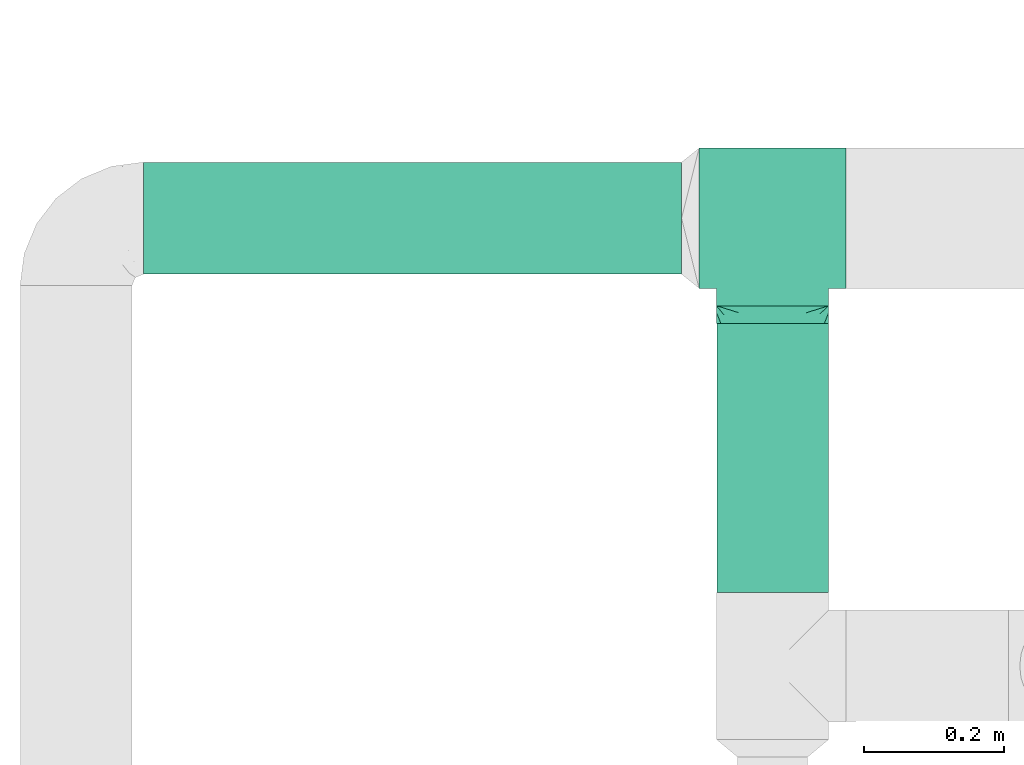
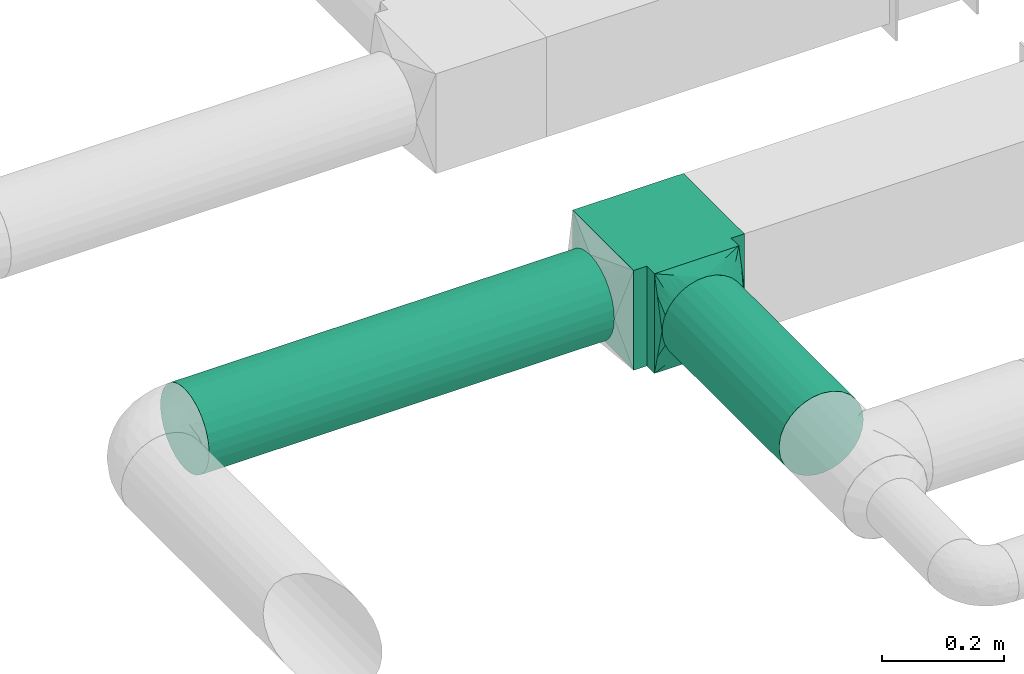
# One storey, part 4 of 12: 2 flow fittings, 2 flow segments.
"""IFC2X3 building model written with IfcOpenShell, lengths in millimetres."""

from ifc_helpers import new_model, entity, si_unit, converted_unit, derived_unit, direction, frame, origin, origin_2d_with_axis, place, context, subcontext, project, spatial, polyline, circle, outline, extrude, faceted_brep, source, transform, mapped, material, type_object, type_shapes, element, save


model = new_model("IFC2X3")

# Units and contexts
model_context = context("Model", 3, precision=0.01, world=origin(), true_north=direction((6.12303176911189e-17, 1.0)))
body_context = subcontext(model_context, "Body", "Model", "MODEL_VIEW")
ifc_project = project(units=[si_unit("LENGTHUNIT", "METRE", prefix="MILLI"), si_unit("AREAUNIT", "SQUARE_METRE"), si_unit("VOLUMEUNIT", "CUBIC_METRE"), converted_unit("PLANEANGLEUNIT", "DEGREE", entity("IfcRatioMeasure", 0.0174532925199433), si_unit("PLANEANGLEUNIT", "RADIAN"), dimensions=[0, 0, 0, 0, 0, 0, 0]), si_unit("MASSUNIT", "GRAM", prefix="KILO"), derived_unit("MASSDENSITYUNIT", [(si_unit("MASSUNIT", "GRAM", prefix="KILO"), 1), (si_unit("LENGTHUNIT", "METRE"), -3)]), si_unit("TIMEUNIT", "SECOND"), si_unit("FREQUENCYUNIT", "HERTZ"), si_unit("THERMODYNAMICTEMPERATUREUNIT", "DEGREE_CELSIUS"), derived_unit("THERMALTRANSMITTANCEUNIT", [(si_unit("MASSUNIT", "GRAM", prefix="KILO"), 1), (si_unit("THERMODYNAMICTEMPERATUREUNIT", "KELVIN"), -1), (si_unit("TIMEUNIT", "SECOND"), -3)]), derived_unit("VOLUMETRICFLOWRATEUNIT", [(si_unit("LENGTHUNIT", "METRE"), 3), (si_unit("TIMEUNIT", "SECOND"), -1)]), si_unit("ELECTRICCURRENTUNIT", "AMPERE"), si_unit("ELECTRICVOLTAGEUNIT", "VOLT"), si_unit("POWERUNIT", "WATT"), si_unit("FORCEUNIT", "NEWTON", prefix="KILO"), si_unit("ILLUMINANCEUNIT", "LUX"), si_unit("LUMINOUSFLUXUNIT", "LUMEN"), si_unit("LUMINOUSINTENSITYUNIT", "CANDELA"), derived_unit("USERDEFINED", [(si_unit("MASSUNIT", "GRAM", prefix="KILO"), -1), (si_unit("LENGTHUNIT", "METRE"), -2), (si_unit("TIMEUNIT", "SECOND"), 3), (si_unit("LUMINOUSFLUXUNIT", "LUMEN"), 1)]), derived_unit("LINEARVELOCITYUNIT", [(si_unit("LENGTHUNIT", "METRE"), 1), (si_unit("TIMEUNIT", "SECOND"), -1)]), si_unit("PRESSUREUNIT", "PASCAL"), derived_unit("USERDEFINED", [(si_unit("LENGTHUNIT", "METRE"), -2), (si_unit("MASSUNIT", "GRAM", prefix="KILO"), 1), (si_unit("TIMEUNIT", "SECOND"), -2)])], contexts=[model_context])

# Site, building, storey
site_placement = place(None, origin())
site = spatial("IfcSite", under=ifc_project, at=site_placement, CompositionType="ELEMENT")
building_placement = place(site_placement, origin())
building = spatial("IfcBuilding", under=site, at=building_placement, CompositionType="ELEMENT")
storey_placement = place(building_placement, frame((0.0, 0.0, 4000.0)))
storey = spatial("IfcBuildingStorey", under=building, at=storey_placement, Name="01 Level", CompositionType="ELEMENT", Elevation=4000.0)

# Flow segments
duct_segment_type = type_object("IfcDuctSegmentType", Name="Round Duct:Air", PredefinedType="NOTDEFINED")
flow_segment_1_placement = place(storey_placement, frame((22287.748982204, -69237.6305015531, 2918.40472776409)))
element("IfcFlowSegment", 1, at=flow_segment_1_placement, inside=storey, type_object=duct_segment_type, Name="Round Duct:Air", ObjectType="Round Duct:Air", context=body_context, shape_type="SweptSolid", body=[
    extrude(circle(Radius=80.0, at=origin_2d_with_axis()), frame((0.0, 81.595272235915, 81.5952722359161), z_axis=(1.0, 0.0, 0.0), x_axis=(0.0, -1.0, 0.0)), (0.0, 0.0, 1.0), 768.241088647822),
])
flow_segment_2_placement = place(storey_placement, frame((23104.3947986159, -69690.234231492, 2918.40472776409)))
element("IfcFlowSegment", 2, at=flow_segment_2_placement, inside=storey, type_object=duct_segment_type, Name="Round Duct:Air", ObjectType="Round Duct:Air", context=body_context, shape_type="SweptSolid", body=[
    extrude(circle(Radius=80.0, at=origin_2d_with_axis()), frame((81.595272235915, 0.0, 81.5952722359161), z_axis=(0.0, 1.0, 0.0), x_axis=(1.0, 0.0, 0.0)), (0.0, 0.0, 1.0), 384.199002174792),
])

# Flow fittings
duct_fitting_type_1 = type_object("IfcDuctFittingType", Name="Air_Rect", PredefinedType="NOTDEFINED")
shared_shape_1 = source(origin(), body_context, "Body", "SweptSolid", [
    extrude(outline(polyline([(-105.0, 43.7500000000001), (-105.0, -156.25), (105.0, -156.25), (105.0, 43.75), (80.0, 43.75), (80.0, 68.7499999999997), (-80.0, 68.7500000000002), (-80.0, 43.7500000000001), (-105.0, 43.7500000000001)])), frame((0.0, -56.25, -100.0), z_axis=(0.0, 0.0, -1.0), x_axis=(1.0, 0.0, 0.0)), (0.0, 0.0, -1.0), 200.0),
])
type_shapes(duct_fitting_type_1, [shared_shape_1])
flow_fitting_1_placement = place(storey_placement, frame((23185.9900708518, -69156.0352293172, 3000.0)))
element("IfcFlowFitting", 3, at=flow_fitting_1_placement, inside=storey, type_object=duct_fitting_type_1, Name="1_001:Air_Rect", ObjectType="1_001:Air_Rect", context=body_context, shape_type="MappedRepresentation", body=[
    mapped(shared_shape_1, transform((0.0, 0.0, 0.0), scale=1.0)),
])
ifc_material = material(Name="Material_Duct")
duct_fitting_type_2 = type_object("IfcDuctFittingType", Name="Air_Multi shape transition_Circ", PredefinedType="NOTDEFINED", material=ifc_material)
shared_shape_2 = source(origin(), body_context, "Body", "Brep", [
    faceted_brep([(25.0, -30.614674589207, -73.9103626009021), (25.0, -22.8665162204521, -75.4515671248636), (25.0, -15.1183578516973, -76.9927716488251), (25.0, -11.3387683887729, -77.7445787366186), (25.0, -7.55917892584856, -78.4963858244121), (25.0, 0.0, -80.0), (25.0, 7.55917891579331, -78.4963858264122), (25.0, 15.1183578315867, -76.9927716528254), (25.0, 18.9924370209918, -76.2221693898446), (25.0, 22.8665162103969, -75.4515671268637), (25.0, 30.6146745892071, -73.9103626009021), (25.0, 37.1031415656363, -69.5749075744073), (25.0, 43.5916085420654, -65.2394525479125), (25.0, 50.0800755184946, -60.9039975214177), (25.0, 56.5685424949238, -56.5685424949229), (25.0, 60.9039975214186, -50.0800755184938), (25.0, 65.2394525479134, -43.5916085420646), (25.0, 69.5749075744082, -37.1031415656355), (25.0, 73.910362600903, -30.6146745892063), (25.0, 75.4515671248645, -22.8665162204514), (25.0, 76.992771648826, -15.1183578516966), (25.0, 77.7445787366195, -11.3387683887722), (25.0, 78.496385824413, -7.55917892584782), (25.0, 80.0, 0.0), (25.0, 78.4963858264131, 7.55917891579322), (25.0, 76.9927716528263, 15.1183578315867), (25.0, 76.2221693898455, 18.9924370209917), (25.0, 75.4515671268647, 22.8665162103968), (25.0, 73.910362600903, 30.614674589207), (25.0, 69.5749075744082, 37.1031415656362), (25.0, 65.2394525479135, 43.5916085420653), (25.0, 60.9039975214187, 50.0800755184945), (25.0, 56.5685424949239, 56.5685424949237), (25.0, 50.0800755184948, 60.9039975214185), (25.0, 43.5916085420656, 65.2394525479133), (25.0, 37.1031415656365, 69.5749075744081), (25.0, 30.6146745892073, 73.9103626009029), (25.0, 22.8665162204525, 75.4515671248644), (25.0, 15.1183578516976, 76.992771648826), (25.0, 11.3387683887732, 77.7445787366195), (25.0, 7.55917892584888, 78.496385824413), (25.0, 0.0, 80.0), (25.0, -7.55917891579327, 78.4963858264132), (25.0, -15.1183578315867, 76.9927716528263), (25.0, -18.9924370209918, 76.2221693898455), (25.0, -22.8665162103969, 75.4515671268647), (25.0, -30.6146745892071, 73.910362600903), (25.0, -37.1031415656362, 69.5749075744082), (25.0, -43.5916085420654, 65.2394525479134), (25.0, -50.0800755184946, 60.9039975214187), (25.0, -56.5685424949237, 56.5685424949239), (25.0, -60.9039975214185, 50.0800755184947), (25.0, -65.2394525479133, 43.5916085420656), (25.0, -69.5749075744081, 37.1031415656364), (25.0, -73.9103626009029, 30.6146745892072), (25.0, -75.4515671248645, 22.8665162204524), (25.0, -76.992771648826, 15.1183578516975), (25.0, -77.7445787366195, 11.3387683887731), (25.0, -78.496385824413, 7.55917892584876), (25.0, -80.0, 0.0), (25.0, -78.4963858264131, -7.55917891579276), (25.0, -76.9927716528262, -15.1183578315862), (25.0, -76.2221693898453, -18.9924370209913), (25.0, -75.4515671268645, -22.8665162103963), (25.0, -73.9103626009028, -30.6146745892065), (25.0, -69.574907574408, -37.1031415656356), (25.0, -65.2394525479132, -43.5916085420648), (25.0, -60.9039975214184, -50.0800755184939), (25.0, -56.5685424949236, -56.5685424949231), (25.0, -50.0800755184945, -60.9039975214178), (25.0, -43.5916085420653, -65.2394525479126), (25.0, -37.1031415656362, -69.5749075744073), (0.0, -80.0, 100.0), (0.0, 80.0, 100.0), (0.0, 80.0, -100.0), (0.0, -80.0, -100.0), (6.50713916945186, -59.1771546577547, 94.7942886644397), (9.76070875417778, -48.7657319866316, 92.1914329966587), (22.0035695847259, -9.588577328877, 82.3971443322195), (19.0071391694519, -19.1771546577542, 84.7942886644389), (16.0107087541778, -28.7657319866313, 87.1914329966584), (13.0142783389037, -38.3543093155085, 89.5885773288778), (12.5000000004112, -69.9443399352347, 76.5204921859004), (9.76070845754317, -80.0, 60.9571661698283), (13.0142779433909, -80.0, 47.9428882264372), (16.0107084575432, -80.0, 35.9571661698279), (19.0071389716954, -80.0, 23.9714441132186), (20.5053542287716, -80.0, 17.978583084914), (22.0035694858477, -80.0, 11.9857220566093), (3.25356948584772, -80.0, 86.9857220566105), (6.50713897169544, -80.0, 73.9714441132194), (3.25356958472593, -69.5885773288778, 97.3971443322206), (3.25356958472592, -80.0, -86.9857216610962), (6.50713916945185, -80.0, -73.9714433221924), (9.76070875417777, -80.0, -60.9571649832887), (13.0142783389037, -80.0, -47.9428866443849), (16.0107087541778, -80.0, -35.9571649832885), (19.0071391694518, -80.0, -23.9714433221921), (22.0035695847259, -80.0, -11.9857216610957), (12.5000000004112, -66.5204921862289, -79.9443399349049), (9.76070845754315, -48.7657329358624, -92.1914332339651), (13.0142779433909, -38.3543105811496, -89.5885776452868), (16.0107084575432, -28.7657329358621, -87.1914332339649), (19.0071389716954, -19.1771552905747, -84.794288822643), (20.5053542287716, -14.382866467931, -83.595716616982), (22.0035694858477, -9.58857764528725, -82.397144411321), (3.25356948584772, -69.5885776452881, -97.3971444113217), (6.50713897169543, -59.1771552905752, -94.7942888226434), (3.25356958472593, 69.5885773288765, -97.3971443322191), (6.50713916945186, 59.1771546577536, -94.7942886644383), (9.76070875417778, 48.7657319866307, -92.1914329966574), (13.0142783389037, 38.3543093155078, -89.5885773288765), (16.0107087541778, 28.7657319866308, -87.1914329966572), (19.0071391694519, 19.1771546577538, -84.7942886644378), (22.0035695847259, 9.58857732887686, -82.3971443322185), (12.5000000004112, 69.9443399352339, -76.5204921858991), (9.76070845754317, 80.0, -60.957166169827), (13.0142779433909, 80.0, -47.942888226436), (16.0107084575432, 80.0, -35.9571661698268), (19.0071389716954, 80.0, -23.9714441132175), (20.5053542287716, 80.0, -17.9785830849129), (22.0035694858477, 80.0, -11.9857220566083), (3.25356948584772, 80.0, -86.985722056609), (6.50713897169544, 80.0, -73.971444113218), (3.25356958472593, 80.0, 86.9857216610977), (6.50713916945185, 80.0, 73.9714433221937), (9.76070875417778, 80.0, 60.9571649832898), (13.0142783389037, 80.0, 47.9428866443859), (16.0107087541778, 80.0, 35.9571649832893), (19.0071391694519, 80.0, 23.9714433221928), (22.0035695847259, 80.0, 11.9857216610963), (12.5000000004112, 66.5204921862283, 79.9443399349061), (9.76070845754316, 48.7657329358616, 92.1914332339665), (13.0142779433909, 38.354310581149, 89.5885776452881), (16.0107084575432, 28.7657329358618, 87.191433233966), (19.0071389716954, 19.1771552905745, 84.794288822644), (20.5053542287716, 14.3828664679309, 83.595716616983), (22.0035694858477, 9.58857764528735, 82.397144411322), (3.25356948584772, 69.5885776452868, 97.3971444113232), (6.50713897169544, 59.1771552905742, 94.7942888226448)], [[[0, 1, 2, 3, 4, 5, 6, 7, 8, 9, 10, 11, 12, 13, 14, 15, 16, 17, 18, 19, 20, 21, 22, 23, 24, 25, 26, 27, 28, 29, 30, 31, 32, 33, 34, 35, 36, 37, 38, 39, 40, 41, 42, 43, 44, 45, 46, 47, 48, 49, 50, 51, 52, 53, 54, 55, 56, 57, 58, 59, 60, 61, 62, 63, 64, 65, 66, 67, 68, 69, 70, 71]], [[72, 73, 74, 75]], [[76, 48, 77]], [[48, 47, 46, 77]], [[78, 79, 80, 81, 77, 46, 45, 44, 43, 42, 41]], [[49, 82, 50]], [[56, 55, 54, 83, 84, 85, 86, 87, 88, 59, 58, 57]], [[82, 72, 89]], [[82, 51, 50]], [[83, 52, 90]], [[91, 72, 82]], [[54, 53, 52, 83]], [[90, 52, 51]], [[51, 82, 89]], [[90, 51, 89]], [[76, 49, 48]], [[49, 76, 91]], [[82, 49, 91]], [[88, 87, 86, 85, 84, 83, 90, 89, 72, 75, 92, 93, 94, 95, 96, 97, 98, 59]], [[93, 66, 94]], [[66, 65, 64, 94]], [[98, 97, 96, 95, 94, 64, 63, 62, 61, 60, 59]], [[67, 99, 68]], [[2, 1, 0, 100, 101, 102, 103, 104, 105, 5, 4, 3]], [[99, 75, 106]], [[99, 69, 68]], [[100, 70, 107]], [[92, 75, 99]], [[0, 71, 70, 100]], [[107, 70, 69]], [[69, 99, 106]], [[107, 69, 106]], [[93, 67, 66]], [[67, 93, 92]], [[99, 67, 92]], [[105, 104, 103, 102, 101, 100, 107, 106, 75, 74, 108, 109, 110, 111, 112, 113, 114, 5]], [[109, 12, 110]], [[12, 11, 10, 110]], [[114, 113, 112, 111, 110, 10, 9, 8, 7, 6, 5]], [[13, 115, 14]], [[20, 19, 18, 116, 117, 118, 119, 120, 121, 23, 22, 21]], [[115, 74, 122]], [[115, 15, 14]], [[116, 16, 123]], [[108, 74, 115]], [[18, 17, 16, 116]], [[123, 16, 15]], [[15, 115, 122]], [[123, 15, 122]], [[109, 13, 12]], [[13, 109, 108]], [[115, 13, 108]], [[74, 73, 124, 125, 126, 127, 128, 129, 130, 23, 121, 120, 119, 118, 117, 116, 123, 122]], [[125, 30, 126]], [[30, 29, 28, 126]], [[130, 129, 128, 127, 126, 28, 27, 26, 25, 24, 23]], [[31, 131, 32]], [[38, 37, 36, 132, 133, 134, 135, 136, 137, 41, 40, 39]], [[131, 73, 138]], [[131, 33, 32]], [[132, 34, 139]], [[124, 73, 131]], [[36, 35, 34, 132]], [[139, 34, 33]], [[33, 131, 138]], [[139, 33, 138]], [[125, 31, 30]], [[31, 125, 124]], [[131, 31, 124]], [[73, 72, 91, 76, 77, 81, 80, 79, 78, 41, 137, 136, 135, 134, 133, 132, 139, 138]]]),
])
type_shapes(duct_fitting_type_2, [shared_shape_2])
flow_fitting_2_placement = place(storey_placement, frame((23185.9900708518, -69281.0352293172, 3000.0), z_axis=(0.0, 0.0, 1.0), x_axis=(0.0, -1.0, 0.0)))
element("IfcFlowFitting", 4, at=flow_fitting_2_placement, inside=storey, type_object=duct_fitting_type_2, material=ifc_material, Name="multi_shape_trans_001:Air_Multi shape transition_Circ", ObjectType="multi_shape_trans_001:Air_Multi shape transition_Circ", context=body_context, shape_type="MappedRepresentation", body=[
    mapped(shared_shape_2, transform((0.0, 0.0, 0.0), scale=1.0)),
])

save(model, "model.ifc")
